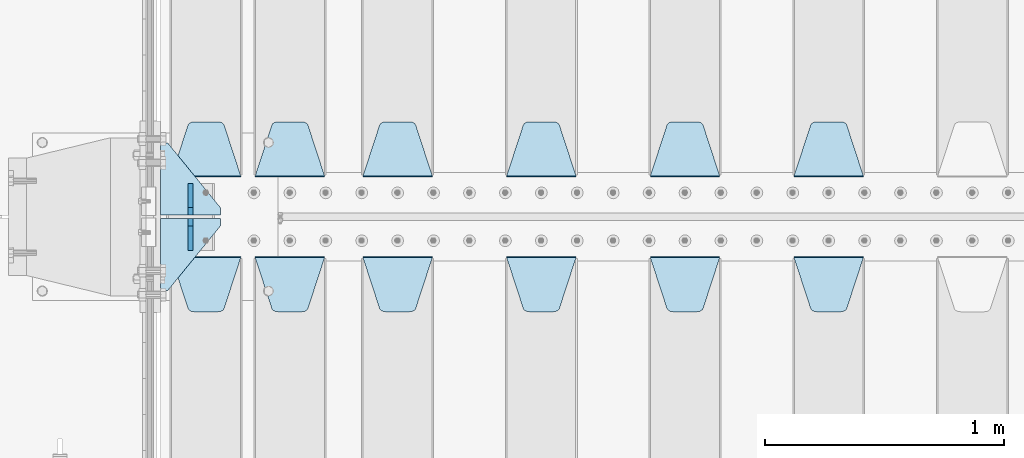
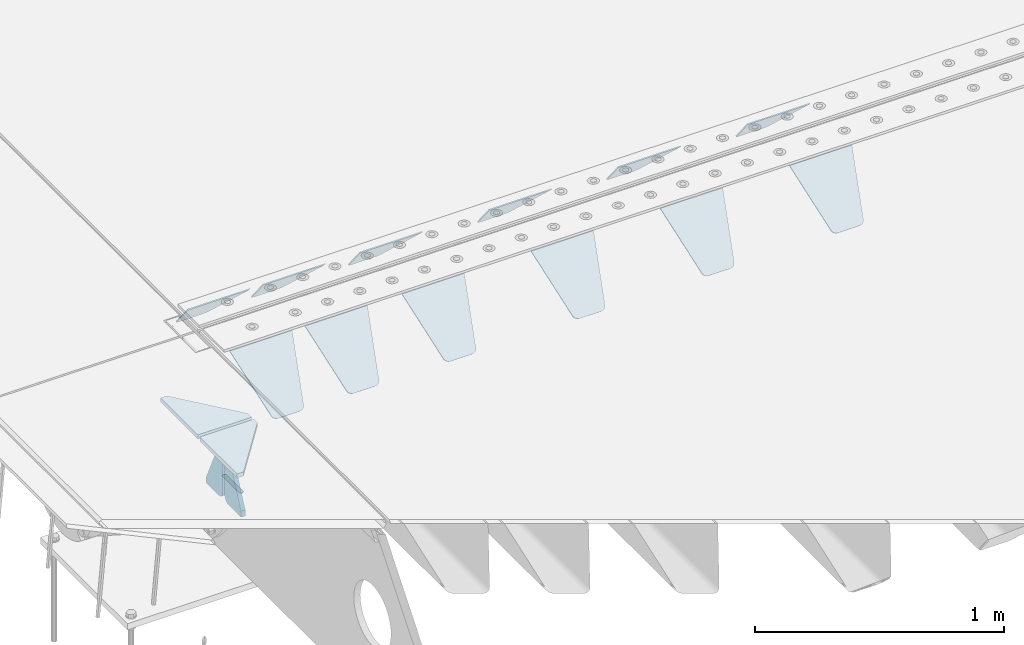
# One storey, part 206 of 257: 16 plates.
"""IFC2X3 building model written with IfcOpenShell, lengths in millimetres."""

from ifc_helpers import new_model, si_unit, frame, origin_with_axes, place, context, subcontext, project, spatial, faceted_brep, material, type_object, element, save


model = new_model("IFC2X3")

# Units and contexts
model_context = context("Model", 3, precision=1e-05, world=origin_with_axes())
body_context = subcontext(model_context, "Body", "Model", "MODEL_VIEW")
ifc_project = project(units=[si_unit("LENGTHUNIT", "METRE", prefix="MILLI"), si_unit("AREAUNIT", "SQUARE_METRE"), si_unit("VOLUMEUNIT", "CUBIC_METRE"), si_unit("MASSUNIT", "GRAM", prefix="KILO"), si_unit("TIMEUNIT", "SECOND"), si_unit("PLANEANGLEUNIT", "RADIAN"), si_unit("SOLIDANGLEUNIT", "STERADIAN"), si_unit("THERMODYNAMICTEMPERATUREUNIT", "DEGREE_CELSIUS"), si_unit("LUMINOUSINTENSITYUNIT", "LUMEN")], contexts=[model_context])

# Site, building, storey
site_placement = place(None, origin_with_axes())
site = spatial("IfcSite", under=ifc_project, at=site_placement, CompositionType="ELEMENT")
building_placement = place(site_placement, origin_with_axes())
building = spatial("IfcBuilding", under=site, at=building_placement, Name="Standard", CompositionType="ELEMENT")
storey_placement = place(building_placement, origin_with_axes())
storey = spatial("IfcBuildingStorey", under=building, at=storey_placement, Name="Undefined", CompositionType="ELEMENT", Elevation=0.0)

# Plates
ifc_material = material(Name="STEEL/S355N")
plate_type_1 = type_object("IfcPlateType", PredefinedType="NOTDEFINED")
plate_1_placement = place(storey_placement, frame((45395.0, 6168.23223304703, -1.76776695296758), z_axis=(0.0, 0.707106781186547, -0.707106781186548), x_axis=(-1.0, 0.0, 0.0)))
element("IfcPlate", 1, at=plate_1_placement, inside=storey, type_object=plate_type_1, material=ifc_material, context=body_context, shape_type="Brep", body=[
    faceted_brep([(0.0, -2.5, 0.0), (69.345504679477, -2.50000000000091, 300.17173142483), (69.345504679477, 2.5, 300.171731424831), (0.0, 2.5, 0.0), (70.927406119954, -2.50000000000091, 304.8974424154), (70.927406119954, 2.5, 304.8974424154), (73.3818627772271, -2.50000000000091, 309.234538108527), (73.3818627772271, 2.49999999999909, 309.234538108527), (76.6187032999587, -2.5, 313.023683126103), (76.6187032999587, 2.5, 313.023683126103), (80.5190132705029, -2.5, 316.125672595372), (80.5190132705029, 2.5, 316.125672595371), (84.9395038596849, -2.5, 318.426546230476), (84.9395038596849, 2.5, 318.426546230477), (89.7177759439219, -2.5, 319.841774983275), (89.7177759439219, 2.5, 319.841774983275), (94.6782862926484, -2.5, 320.319366455079), (94.6782862926484, 2.5, 320.319366455079), (195.321713707352, -2.5, 320.319366455079), (195.321713707352, 2.5, 320.319366455079), (200.282224056078, -2.5, 319.841774983275), (200.282224056078, 2.49999999999909, 319.841774983275), (205.060496140315, -2.5, 318.426546230476), (205.060496140315, 2.49999999999909, 318.426546230475), (209.480986729497, -2.5, 316.125672595371), (209.480986729497, 2.5, 316.125672595371), (213.381296700041, -2.50000000000091, 313.023683126102), (213.381296700041, 2.5, 313.023683126103), (216.618137222766, -2.50000000000091, 309.234538108527), (216.618137222766, 2.5, 309.234538108527), (219.072593880039, -2.5, 304.897442415399), (219.072593880039, 2.5, 304.897442415399), (220.654495320523, -2.50000000000091, 300.17173142483), (220.654495320523, 2.5, 300.171731424831), (290.0, -2.50000000000091, 0.0), (290.0, 2.5, 9.09494701772928e-13)], [[[0, 1, 2, 3]], [[1, 4, 5, 2]], [[4, 6, 7, 5]], [[6, 8, 9, 7]], [[8, 10, 11, 9]], [[10, 12, 13, 11]], [[12, 14, 15, 13]], [[14, 16, 17, 15]], [[16, 18, 19, 17]], [[18, 20, 21, 19]], [[20, 22, 23, 21]], [[22, 24, 25, 23]], [[24, 26, 27, 25]], [[26, 28, 29, 27]], [[28, 30, 31, 29]], [[30, 32, 33, 31]], [[32, 34, 35, 33]], [[34, 0, 3, 35]], [[5, 7, 9, 11, 13, 15, 17, 19, 21, 23, 25, 27, 29, 31, 33, 35, 3, 2]], [[34, 32, 30, 28, 26, 24, 22, 20, 18, 16, 14, 12, 10, 8, 6, 4, 1, 0]]]),
])
plate_2_placement = place(storey_placement, frame((44795.0, 6168.23223304703, -1.76776695296758), z_axis=(0.0, 0.707106781186547, -0.707106781186548), x_axis=(-1.0, 0.0, 0.0)))
element("IfcPlate", 2, at=plate_2_placement, inside=storey, type_object=plate_type_1, material=ifc_material, context=body_context, shape_type="Brep", body=[
    faceted_brep([(0.0, -2.5, 0.0), (69.345504679477, -2.50000000000091, 300.17173142483), (69.345504679477, 2.5, 300.171731424831), (0.0, 2.5, 0.0), (70.927406119954, -2.50000000000091, 304.8974424154), (70.927406119954, 2.5, 304.8974424154), (73.3818627772271, -2.50000000000091, 309.234538108527), (73.3818627772271, 2.49999999999909, 309.234538108527), (76.6187032999587, -2.5, 313.023683126103), (76.6187032999587, 2.5, 313.023683126103), (80.5190132705029, -2.5, 316.125672595372), (80.5190132705029, 2.5, 316.125672595371), (84.9395038596849, -2.5, 318.426546230476), (84.9395038596849, 2.5, 318.426546230477), (89.7177759439219, -2.5, 319.841774983275), (89.7177759439219, 2.5, 319.841774983275), (94.6782862926484, -2.5, 320.319366455079), (94.6782862926484, 2.5, 320.319366455079), (195.321713707352, -2.5, 320.319366455079), (195.321713707352, 2.5, 320.319366455079), (200.282224056078, -2.5, 319.841774983275), (200.282224056078, 2.49999999999909, 319.841774983275), (205.060496140315, -2.5, 318.426546230476), (205.060496140315, 2.49999999999909, 318.426546230475), (209.480986729497, -2.5, 316.125672595371), (209.480986729497, 2.5, 316.125672595371), (213.381296700041, -2.50000000000091, 313.023683126102), (213.381296700041, 2.5, 313.023683126103), (216.618137222766, -2.50000000000091, 309.234538108527), (216.618137222766, 2.5, 309.234538108527), (219.072593880039, -2.5, 304.897442415399), (219.072593880039, 2.5, 304.897442415399), (220.654495320523, -2.50000000000091, 300.17173142483), (220.654495320523, 2.5, 300.171731424831), (290.0, -2.50000000000091, 0.0), (290.0, 2.5, 9.09494701772928e-13)], [[[0, 1, 2, 3]], [[1, 4, 5, 2]], [[4, 6, 7, 5]], [[6, 8, 9, 7]], [[8, 10, 11, 9]], [[10, 12, 13, 11]], [[12, 14, 15, 13]], [[14, 16, 17, 15]], [[16, 18, 19, 17]], [[18, 20, 21, 19]], [[20, 22, 23, 21]], [[22, 24, 25, 23]], [[24, 26, 27, 25]], [[26, 28, 29, 27]], [[28, 30, 31, 29]], [[30, 32, 33, 31]], [[32, 34, 35, 33]], [[34, 0, 3, 35]], [[5, 7, 9, 11, 13, 15, 17, 19, 21, 23, 25, 27, 29, 31, 33, 35, 3, 2]], [[34, 32, 30, 28, 26, 24, 22, 20, 18, 16, 14, 12, 10, 8, 6, 4, 1, 0]]]),
])
plate_3_placement = place(storey_placement, frame((44195.0, 6168.23223304703, -1.76776695296758), z_axis=(0.0, 0.707106781186547, -0.707106781186548), x_axis=(-1.0, 0.0, 0.0)))
element("IfcPlate", 3, at=plate_3_placement, inside=storey, type_object=plate_type_1, material=ifc_material, context=body_context, shape_type="Brep", body=[
    faceted_brep([(0.0, -2.5, 0.0), (69.345504679477, -2.50000000000091, 300.17173142483), (69.345504679477, 2.5, 300.171731424831), (0.0, 2.5, 0.0), (70.927406119954, -2.50000000000091, 304.8974424154), (70.927406119954, 2.5, 304.8974424154), (73.3818627772271, -2.50000000000091, 309.234538108527), (73.3818627772271, 2.49999999999909, 309.234538108527), (76.6187032999587, -2.5, 313.023683126103), (76.6187032999587, 2.5, 313.023683126103), (80.5190132705029, -2.5, 316.125672595372), (80.5190132705029, 2.5, 316.125672595371), (84.9395038596849, -2.5, 318.426546230476), (84.9395038596849, 2.5, 318.426546230477), (89.7177759439219, -2.5, 319.841774983275), (89.7177759439219, 2.5, 319.841774983275), (94.6782862926484, -2.5, 320.319366455079), (94.6782862926484, 2.5, 320.319366455079), (195.321713707352, -2.5, 320.319366455079), (195.321713707352, 2.5, 320.319366455079), (200.282224056078, -2.5, 319.841774983275), (200.282224056078, 2.49999999999909, 319.841774983275), (205.060496140315, -2.5, 318.426546230476), (205.060496140315, 2.49999999999909, 318.426546230475), (209.480986729497, -2.5, 316.125672595371), (209.480986729497, 2.5, 316.125672595371), (213.381296700041, -2.50000000000091, 313.023683126102), (213.381296700041, 2.5, 313.023683126103), (216.618137222766, -2.50000000000091, 309.234538108527), (216.618137222766, 2.5, 309.234538108527), (219.072593880039, -2.5, 304.897442415399), (219.072593880039, 2.5, 304.897442415399), (220.654495320523, -2.50000000000091, 300.17173142483), (220.654495320523, 2.5, 300.171731424831), (290.0, -2.50000000000091, 0.0), (290.0, 2.5, 9.09494701772928e-13)], [[[0, 1, 2, 3]], [[1, 4, 5, 2]], [[4, 6, 7, 5]], [[6, 8, 9, 7]], [[8, 10, 11, 9]], [[10, 12, 13, 11]], [[12, 14, 15, 13]], [[14, 16, 17, 15]], [[16, 18, 19, 17]], [[18, 20, 21, 19]], [[20, 22, 23, 21]], [[22, 24, 25, 23]], [[24, 26, 27, 25]], [[26, 28, 29, 27]], [[28, 30, 31, 29]], [[30, 32, 33, 31]], [[32, 34, 35, 33]], [[34, 0, 3, 35]], [[5, 7, 9, 11, 13, 15, 17, 19, 21, 23, 25, 27, 29, 31, 33, 35, 3, 2]], [[34, 32, 30, 28, 26, 24, 22, 20, 18, 16, 14, 12, 10, 8, 6, 4, 1, 0]]]),
])
plate_4_placement = place(storey_placement, frame((43595.0, 6168.23223304703, -1.76776695296758), z_axis=(0.0, 0.707106781186547, -0.707106781186548), x_axis=(-1.0, 0.0, 0.0)))
element("IfcPlate", 4, at=plate_4_placement, inside=storey, type_object=plate_type_1, material=ifc_material, context=body_context, shape_type="Brep", body=[
    faceted_brep([(0.0, -2.5, 0.0), (69.345504679477, -2.50000000000091, 300.17173142483), (69.345504679477, 2.5, 300.171731424831), (0.0, 2.5, 0.0), (70.927406119954, -2.50000000000091, 304.8974424154), (70.927406119954, 2.5, 304.8974424154), (73.3818627772271, -2.50000000000091, 309.234538108527), (73.3818627772271, 2.49999999999909, 309.234538108527), (76.6187032999587, -2.5, 313.023683126103), (76.6187032999587, 2.5, 313.023683126103), (80.5190132705029, -2.5, 316.125672595372), (80.5190132705029, 2.5, 316.125672595371), (84.9395038596849, -2.5, 318.426546230476), (84.9395038596849, 2.5, 318.426546230477), (89.7177759439219, -2.5, 319.841774983275), (89.7177759439219, 2.5, 319.841774983275), (94.6782862926484, -2.5, 320.319366455079), (94.6782862926484, 2.5, 320.319366455079), (195.321713707352, -2.5, 320.319366455079), (195.321713707352, 2.5, 320.319366455079), (200.282224056078, -2.5, 319.841774983275), (200.282224056078, 2.49999999999909, 319.841774983275), (205.060496140315, -2.5, 318.426546230476), (205.060496140315, 2.49999999999909, 318.426546230475), (209.480986729497, -2.5, 316.125672595371), (209.480986729497, 2.5, 316.125672595371), (213.381296700041, -2.50000000000091, 313.023683126102), (213.381296700041, 2.5, 313.023683126103), (216.618137222766, -2.50000000000091, 309.234538108527), (216.618137222766, 2.5, 309.234538108527), (219.072593880039, -2.5, 304.897442415399), (219.072593880039, 2.5, 304.897442415399), (220.654495320523, -2.50000000000091, 300.17173142483), (220.654495320523, 2.5, 300.171731424831), (290.0, -2.50000000000091, 0.0), (290.0, 2.5, 9.09494701772928e-13)], [[[0, 1, 2, 3]], [[1, 4, 5, 2]], [[4, 6, 7, 5]], [[6, 8, 9, 7]], [[8, 10, 11, 9]], [[10, 12, 13, 11]], [[12, 14, 15, 13]], [[14, 16, 17, 15]], [[16, 18, 19, 17]], [[18, 20, 21, 19]], [[20, 22, 23, 21]], [[22, 24, 25, 23]], [[24, 26, 27, 25]], [[26, 28, 29, 27]], [[28, 30, 31, 29]], [[30, 32, 33, 31]], [[32, 34, 35, 33]], [[34, 0, 3, 35]], [[5, 7, 9, 11, 13, 15, 17, 19, 21, 23, 25, 27, 29, 31, 33, 35, 3, 2]], [[34, 32, 30, 28, 26, 24, 22, 20, 18, 16, 14, 12, 10, 8, 6, 4, 1, 0]]]),
])
plate_5_placement = place(storey_placement, frame((43145.0, 6168.23223304703, -1.76776695296758), z_axis=(0.0, 0.707106781186547, -0.707106781186548), x_axis=(-1.0, 0.0, 0.0)))
element("IfcPlate", 5, at=plate_5_placement, inside=storey, type_object=plate_type_1, material=ifc_material, context=body_context, shape_type="Brep", body=[
    faceted_brep([(0.0, -2.5, 0.0), (69.345504679477, -2.50000000000091, 300.17173142483), (69.345504679477, 2.5, 300.171731424831), (0.0, 2.5, 0.0), (70.927406119954, -2.50000000000091, 304.8974424154), (70.927406119954, 2.5, 304.8974424154), (73.3818627772271, -2.50000000000091, 309.234538108527), (73.3818627772271, 2.49999999999909, 309.234538108527), (76.6187032999587, -2.5, 313.023683126103), (76.6187032999587, 2.5, 313.023683126103), (80.5190132705029, -2.5, 316.125672595372), (80.5190132705029, 2.5, 316.125672595371), (84.9395038596849, -2.5, 318.426546230476), (84.9395038596849, 2.5, 318.426546230477), (89.7177759439219, -2.5, 319.841774983275), (89.7177759439219, 2.5, 319.841774983275), (94.6782862926484, -2.5, 320.319366455079), (94.6782862926484, 2.5, 320.319366455079), (195.321713707352, -2.5, 320.319366455079), (195.321713707352, 2.5, 320.319366455079), (200.282224056078, -2.5, 319.841774983275), (200.282224056078, 2.49999999999909, 319.841774983275), (205.060496140315, -2.5, 318.426546230476), (205.060496140315, 2.49999999999909, 318.426546230475), (209.480986729497, -2.5, 316.125672595371), (209.480986729497, 2.5, 316.125672595371), (213.381296700041, -2.50000000000091, 313.023683126102), (213.381296700041, 2.5, 313.023683126103), (216.618137222766, -2.50000000000091, 309.234538108527), (216.618137222766, 2.5, 309.234538108527), (219.072593880039, -2.5, 304.897442415399), (219.072593880039, 2.5, 304.897442415399), (220.654495320523, -2.50000000000091, 300.17173142483), (220.654495320523, 2.5, 300.171731424831), (290.0, -2.50000000000091, 0.0), (290.0, 2.5, 9.09494701772928e-13)], [[[0, 1, 2, 3]], [[1, 4, 5, 2]], [[4, 6, 7, 5]], [[6, 8, 9, 7]], [[8, 10, 11, 9]], [[10, 12, 13, 11]], [[12, 14, 15, 13]], [[14, 16, 17, 15]], [[16, 18, 19, 17]], [[18, 20, 21, 19]], [[20, 22, 23, 21]], [[22, 24, 25, 23]], [[24, 26, 27, 25]], [[26, 28, 29, 27]], [[28, 30, 31, 29]], [[30, 32, 33, 31]], [[32, 34, 35, 33]], [[34, 0, 3, 35]], [[5, 7, 9, 11, 13, 15, 17, 19, 21, 23, 25, 27, 29, 31, 33, 35, 3, 2]], [[34, 32, 30, 28, 26, 24, 22, 20, 18, 16, 14, 12, 10, 8, 6, 4, 1, 0]]]),
])
plate_6_placement = place(storey_placement, frame((45105.0, 5831.76776695594, -1.767766952965), z_axis=(0.0, -0.707106781186548, -0.707106781186547), x_axis=(1.0, 0.0, 0.0)))
element("IfcPlate", 6, at=plate_6_placement, inside=storey, type_object=plate_type_1, material=ifc_material, context=body_context, shape_type="Brep", body=[
    faceted_brep([(0.0, -2.5, 0.0), (69.345504679477, -2.50000000000091, 300.17173142483), (69.345504679477, 2.5, 300.171731424831), (0.0, 2.5, 0.0), (70.927406119954, -2.50000000000091, 304.8974424154), (70.927406119954, 2.5, 304.8974424154), (73.3818627772271, -2.50000000000091, 309.234538108527), (73.3818627772271, 2.49999999999909, 309.234538108527), (76.6187032999587, -2.5, 313.023683126103), (76.6187032999587, 2.5, 313.023683126103), (80.5190132705029, -2.5, 316.125672595372), (80.5190132705029, 2.5, 316.125672595371), (84.9395038596849, -2.5, 318.426546230476), (84.9395038596849, 2.5, 318.426546230477), (89.7177759439219, -2.5, 319.841774983275), (89.7177759439219, 2.5, 319.841774983275), (94.6782862926484, -2.5, 320.319366455079), (94.6782862926484, 2.5, 320.319366455079), (195.321713707352, -2.5, 320.319366455079), (195.321713707352, 2.5, 320.319366455079), (200.282224056078, -2.5, 319.841774983275), (200.282224056078, 2.49999999999909, 319.841774983275), (205.060496140315, -2.5, 318.426546230476), (205.060496140315, 2.49999999999909, 318.426546230475), (209.480986729497, -2.5, 316.125672595371), (209.480986729497, 2.5, 316.125672595371), (213.381296700041, -2.50000000000091, 313.023683126102), (213.381296700041, 2.5, 313.023683126103), (216.618137222766, -2.50000000000091, 309.234538108527), (216.618137222766, 2.5, 309.234538108527), (219.072593880039, -2.5, 304.897442415399), (219.072593880039, 2.5, 304.897442415399), (220.654495320523, -2.50000000000091, 300.17173142483), (220.654495320523, 2.5, 300.171731424831), (290.0, -2.50000000000091, 0.0), (290.0, 2.5, 9.09494701772928e-13)], [[[0, 1, 2, 3]], [[1, 4, 5, 2]], [[4, 6, 7, 5]], [[6, 8, 9, 7]], [[8, 10, 11, 9]], [[10, 12, 13, 11]], [[12, 14, 15, 13]], [[14, 16, 17, 15]], [[16, 18, 19, 17]], [[18, 20, 21, 19]], [[20, 22, 23, 21]], [[22, 24, 25, 23]], [[24, 26, 27, 25]], [[26, 28, 29, 27]], [[28, 30, 31, 29]], [[30, 32, 33, 31]], [[32, 34, 35, 33]], [[34, 0, 3, 35]], [[5, 7, 9, 11, 13, 15, 17, 19, 21, 23, 25, 27, 29, 31, 33, 35, 3, 2]], [[34, 32, 30, 28, 26, 24, 22, 20, 18, 16, 14, 12, 10, 8, 6, 4, 1, 0]]]),
])
plate_7_placement = place(storey_placement, frame((44505.0, 5831.76776695594, -1.767766952965), z_axis=(0.0, -0.707106781186548, -0.707106781186547), x_axis=(1.0, 0.0, 0.0)))
element("IfcPlate", 7, at=plate_7_placement, inside=storey, type_object=plate_type_1, material=ifc_material, context=body_context, shape_type="Brep", body=[
    faceted_brep([(0.0, -2.5, 0.0), (69.345504679477, -2.50000000000091, 300.17173142483), (69.345504679477, 2.5, 300.171731424831), (0.0, 2.5, 0.0), (70.927406119954, -2.50000000000091, 304.8974424154), (70.927406119954, 2.5, 304.8974424154), (73.3818627772271, -2.50000000000091, 309.234538108527), (73.3818627772271, 2.49999999999909, 309.234538108527), (76.6187032999587, -2.5, 313.023683126103), (76.6187032999587, 2.5, 313.023683126103), (80.5190132705029, -2.5, 316.125672595372), (80.5190132705029, 2.5, 316.125672595371), (84.9395038596849, -2.5, 318.426546230476), (84.9395038596849, 2.5, 318.426546230477), (89.7177759439219, -2.5, 319.841774983275), (89.7177759439219, 2.5, 319.841774983275), (94.6782862926484, -2.5, 320.319366455079), (94.6782862926484, 2.5, 320.319366455079), (195.321713707352, -2.5, 320.319366455079), (195.321713707352, 2.5, 320.319366455079), (200.282224056078, -2.5, 319.841774983275), (200.282224056078, 2.49999999999909, 319.841774983275), (205.060496140315, -2.5, 318.426546230476), (205.060496140315, 2.49999999999909, 318.426546230475), (209.480986729497, -2.5, 316.125672595371), (209.480986729497, 2.5, 316.125672595371), (213.381296700041, -2.50000000000091, 313.023683126102), (213.381296700041, 2.5, 313.023683126103), (216.618137222766, -2.50000000000091, 309.234538108527), (216.618137222766, 2.5, 309.234538108527), (219.072593880039, -2.5, 304.897442415399), (219.072593880039, 2.5, 304.897442415399), (220.654495320523, -2.50000000000091, 300.17173142483), (220.654495320523, 2.5, 300.171731424831), (290.0, -2.50000000000091, 0.0), (290.0, 2.5, 9.09494701772928e-13)], [[[0, 1, 2, 3]], [[1, 4, 5, 2]], [[4, 6, 7, 5]], [[6, 8, 9, 7]], [[8, 10, 11, 9]], [[10, 12, 13, 11]], [[12, 14, 15, 13]], [[14, 16, 17, 15]], [[16, 18, 19, 17]], [[18, 20, 21, 19]], [[20, 22, 23, 21]], [[22, 24, 25, 23]], [[24, 26, 27, 25]], [[26, 28, 29, 27]], [[28, 30, 31, 29]], [[30, 32, 33, 31]], [[32, 34, 35, 33]], [[34, 0, 3, 35]], [[5, 7, 9, 11, 13, 15, 17, 19, 21, 23, 25, 27, 29, 31, 33, 35, 3, 2]], [[34, 32, 30, 28, 26, 24, 22, 20, 18, 16, 14, 12, 10, 8, 6, 4, 1, 0]]]),
])
plate_8_placement = place(storey_placement, frame((43905.0, 5831.76776695594, -1.767766952965), z_axis=(0.0, -0.707106781186548, -0.707106781186547), x_axis=(1.0, 0.0, 0.0)))
element("IfcPlate", 8, at=plate_8_placement, inside=storey, type_object=plate_type_1, material=ifc_material, context=body_context, shape_type="Brep", body=[
    faceted_brep([(0.0, -2.5, 0.0), (69.345504679477, -2.50000000000091, 300.17173142483), (69.345504679477, 2.5, 300.171731424831), (0.0, 2.5, 0.0), (70.927406119954, -2.50000000000091, 304.8974424154), (70.927406119954, 2.5, 304.8974424154), (73.3818627772271, -2.50000000000091, 309.234538108527), (73.3818627772271, 2.49999999999909, 309.234538108527), (76.6187032999587, -2.5, 313.023683126103), (76.6187032999587, 2.5, 313.023683126103), (80.5190132705029, -2.5, 316.125672595372), (80.5190132705029, 2.5, 316.125672595371), (84.9395038596849, -2.5, 318.426546230476), (84.9395038596849, 2.5, 318.426546230477), (89.7177759439219, -2.5, 319.841774983275), (89.7177759439219, 2.5, 319.841774983275), (94.6782862926484, -2.5, 320.319366455079), (94.6782862926484, 2.5, 320.319366455079), (195.321713707352, -2.5, 320.319366455079), (195.321713707352, 2.5, 320.319366455079), (200.282224056078, -2.5, 319.841774983275), (200.282224056078, 2.49999999999909, 319.841774983275), (205.060496140315, -2.5, 318.426546230476), (205.060496140315, 2.49999999999909, 318.426546230475), (209.480986729497, -2.5, 316.125672595371), (209.480986729497, 2.5, 316.125672595371), (213.381296700041, -2.50000000000091, 313.023683126102), (213.381296700041, 2.5, 313.023683126103), (216.618137222766, -2.50000000000091, 309.234538108527), (216.618137222766, 2.5, 309.234538108527), (219.072593880039, -2.5, 304.897442415399), (219.072593880039, 2.5, 304.897442415399), (220.654495320523, -2.50000000000091, 300.17173142483), (220.654495320523, 2.5, 300.171731424831), (290.0, -2.50000000000091, 0.0), (290.0, 2.5, 9.09494701772928e-13)], [[[0, 1, 2, 3]], [[1, 4, 5, 2]], [[4, 6, 7, 5]], [[6, 8, 9, 7]], [[8, 10, 11, 9]], [[10, 12, 13, 11]], [[12, 14, 15, 13]], [[14, 16, 17, 15]], [[16, 18, 19, 17]], [[18, 20, 21, 19]], [[20, 22, 23, 21]], [[22, 24, 25, 23]], [[24, 26, 27, 25]], [[26, 28, 29, 27]], [[28, 30, 31, 29]], [[30, 32, 33, 31]], [[32, 34, 35, 33]], [[34, 0, 3, 35]], [[5, 7, 9, 11, 13, 15, 17, 19, 21, 23, 25, 27, 29, 31, 33, 35, 3, 2]], [[34, 32, 30, 28, 26, 24, 22, 20, 18, 16, 14, 12, 10, 8, 6, 4, 1, 0]]]),
])
plate_9_placement = place(storey_placement, frame((43305.0, 5831.76776695594, -1.767766952965), z_axis=(0.0, -0.707106781186548, -0.707106781186547), x_axis=(1.0, 0.0, 0.0)))
element("IfcPlate", 9, at=plate_9_placement, inside=storey, type_object=plate_type_1, material=ifc_material, context=body_context, shape_type="Brep", body=[
    faceted_brep([(0.0, -2.5, 0.0), (69.345504679477, -2.50000000000091, 300.17173142483), (69.345504679477, 2.5, 300.171731424831), (0.0, 2.5, 0.0), (70.927406119954, -2.50000000000091, 304.8974424154), (70.927406119954, 2.5, 304.8974424154), (73.3818627772271, -2.50000000000091, 309.234538108527), (73.3818627772271, 2.49999999999909, 309.234538108527), (76.6187032999587, -2.5, 313.023683126103), (76.6187032999587, 2.5, 313.023683126103), (80.5190132705029, -2.5, 316.125672595372), (80.5190132705029, 2.5, 316.125672595371), (84.9395038596849, -2.5, 318.426546230476), (84.9395038596849, 2.5, 318.426546230477), (89.7177759439219, -2.5, 319.841774983275), (89.7177759439219, 2.5, 319.841774983275), (94.6782862926484, -2.5, 320.319366455079), (94.6782862926484, 2.5, 320.319366455079), (195.321713707352, -2.5, 320.319366455079), (195.321713707352, 2.5, 320.319366455079), (200.282224056078, -2.5, 319.841774983275), (200.282224056078, 2.49999999999909, 319.841774983275), (205.060496140315, -2.5, 318.426546230476), (205.060496140315, 2.49999999999909, 318.426546230475), (209.480986729497, -2.5, 316.125672595371), (209.480986729497, 2.5, 316.125672595371), (213.381296700041, -2.50000000000091, 313.023683126102), (213.381296700041, 2.5, 313.023683126103), (216.618137222766, -2.50000000000091, 309.234538108527), (216.618137222766, 2.5, 309.234538108527), (219.072593880039, -2.5, 304.897442415399), (219.072593880039, 2.5, 304.897442415399), (220.654495320523, -2.50000000000091, 300.17173142483), (220.654495320523, 2.5, 300.171731424831), (290.0, -2.50000000000091, 0.0), (290.0, 2.5, 9.09494701772928e-13)], [[[0, 1, 2, 3]], [[1, 4, 5, 2]], [[4, 6, 7, 5]], [[6, 8, 9, 7]], [[8, 10, 11, 9]], [[10, 12, 13, 11]], [[12, 14, 15, 13]], [[14, 16, 17, 15]], [[16, 18, 19, 17]], [[18, 20, 21, 19]], [[20, 22, 23, 21]], [[22, 24, 25, 23]], [[24, 26, 27, 25]], [[26, 28, 29, 27]], [[28, 30, 31, 29]], [[30, 32, 33, 31]], [[32, 34, 35, 33]], [[34, 0, 3, 35]], [[5, 7, 9, 11, 13, 15, 17, 19, 21, 23, 25, 27, 29, 31, 33, 35, 3, 2]], [[34, 32, 30, 28, 26, 24, 22, 20, 18, 16, 14, 12, 10, 8, 6, 4, 1, 0]]]),
])
plate_10_placement = place(storey_placement, frame((42855.0, 5831.76776695594, -1.767766952965), z_axis=(0.0, -0.707106781186548, -0.707106781186547), x_axis=(1.0, 0.0, 0.0)))
element("IfcPlate", 10, at=plate_10_placement, inside=storey, type_object=plate_type_1, material=ifc_material, context=body_context, shape_type="Brep", body=[
    faceted_brep([(0.0, -2.5, 0.0), (69.345504679477, -2.50000000000091, 300.17173142483), (69.345504679477, 2.5, 300.171731424831), (0.0, 2.5, 0.0), (70.927406119954, -2.50000000000091, 304.8974424154), (70.927406119954, 2.5, 304.8974424154), (73.3818627772271, -2.50000000000091, 309.234538108527), (73.3818627772271, 2.49999999999909, 309.234538108527), (76.6187032999587, -2.5, 313.023683126103), (76.6187032999587, 2.5, 313.023683126103), (80.5190132705029, -2.5, 316.125672595372), (80.5190132705029, 2.5, 316.125672595371), (84.9395038596849, -2.5, 318.426546230476), (84.9395038596849, 2.5, 318.426546230477), (89.7177759439219, -2.5, 319.841774983275), (89.7177759439219, 2.5, 319.841774983275), (94.6782862926484, -2.5, 320.319366455079), (94.6782862926484, 2.5, 320.319366455079), (195.321713707352, -2.5, 320.319366455079), (195.321713707352, 2.5, 320.319366455079), (200.282224056078, -2.5, 319.841774983275), (200.282224056078, 2.49999999999909, 319.841774983275), (205.060496140315, -2.5, 318.426546230476), (205.060496140315, 2.49999999999909, 318.426546230475), (209.480986729497, -2.5, 316.125672595371), (209.480986729497, 2.5, 316.125672595371), (213.381296700041, -2.50000000000091, 313.023683126102), (213.381296700041, 2.5, 313.023683126103), (216.618137222766, -2.50000000000091, 309.234538108527), (216.618137222766, 2.5, 309.234538108527), (219.072593880039, -2.5, 304.897442415399), (219.072593880039, 2.5, 304.897442415399), (220.654495320523, -2.50000000000091, 300.17173142483), (220.654495320523, 2.5, 300.171731424831), (290.0, -2.50000000000091, 0.0), (290.0, 2.5, 9.09494701772928e-13)], [[[0, 1, 2, 3]], [[1, 4, 5, 2]], [[4, 6, 7, 5]], [[6, 8, 9, 7]], [[8, 10, 11, 9]], [[10, 12, 13, 11]], [[12, 14, 15, 13]], [[14, 16, 17, 15]], [[16, 18, 19, 17]], [[18, 20, 21, 19]], [[20, 22, 23, 21]], [[22, 24, 25, 23]], [[24, 26, 27, 25]], [[26, 28, 29, 27]], [[28, 30, 31, 29]], [[30, 32, 33, 31]], [[32, 34, 35, 33]], [[34, 0, 3, 35]], [[5, 7, 9, 11, 13, 15, 17, 19, 21, 23, 25, 27, 29, 31, 33, 35, 3, 2]], [[34, 32, 30, 28, 26, 24, 22, 20, 18, 16, 14, 12, 10, 8, 6, 4, 1, 0]]]),
])
plate_11_placement = place(storey_placement, frame((42795.0, 6168.23223304703, -1.76776695296758), z_axis=(0.0, 0.707106781186547, -0.707106781186548), x_axis=(-1.0, 0.0, 0.0)))
element("IfcPlate", 11, at=plate_11_placement, inside=storey, type_object=plate_type_1, material=ifc_material, context=body_context, shape_type="Brep", body=[
    faceted_brep([(0.0, -2.5, 0.0), (69.345504679477, -2.50000000000091, 300.17173142483), (69.345504679477, 2.5, 300.171731424831), (0.0, 2.5, 0.0), (70.927406119954, -2.50000000000091, 304.8974424154), (70.927406119954, 2.5, 304.8974424154), (73.3818627772271, -2.50000000000091, 309.234538108527), (73.3818627772271, 2.49999999999909, 309.234538108527), (76.6187032999587, -2.5, 313.023683126103), (76.6187032999587, 2.5, 313.023683126103), (80.5190132705029, -2.5, 316.125672595372), (80.5190132705029, 2.5, 316.125672595371), (84.9395038596849, -2.5, 318.426546230476), (84.9395038596849, 2.5, 318.426546230477), (89.7177759439219, -2.5, 319.841774983275), (89.7177759439219, 2.5, 319.841774983275), (94.6782862926484, -2.5, 320.319366455079), (94.6782862926484, 2.5, 320.319366455079), (195.321713707352, -2.5, 320.319366455079), (195.321713707352, 2.5, 320.319366455079), (200.282224056078, -2.5, 319.841774983275), (200.282224056078, 2.49999999999909, 319.841774983275), (205.060496140315, -2.5, 318.426546230476), (205.060496140315, 2.49999999999909, 318.426546230475), (209.480986729497, -2.5, 316.125672595371), (209.480986729497, 2.5, 316.125672595371), (213.381296700041, -2.50000000000091, 313.023683126102), (213.381296700041, 2.5, 313.023683126103), (216.618137222766, -2.50000000000091, 309.234538108527), (216.618137222766, 2.5, 309.234538108527), (219.072593880039, -2.5, 304.897442415399), (219.072593880039, 2.5, 304.897442415399), (220.654495320523, -2.50000000000091, 300.17173142483), (220.654495320523, 2.5, 300.171731424831), (290.0, -2.50000000000091, 0.0), (290.0, 2.5, 9.09494701772928e-13)], [[[0, 1, 2, 3]], [[1, 4, 5, 2]], [[4, 6, 7, 5]], [[6, 8, 9, 7]], [[8, 10, 11, 9]], [[10, 12, 13, 11]], [[12, 14, 15, 13]], [[14, 16, 17, 15]], [[16, 18, 19, 17]], [[18, 20, 21, 19]], [[20, 22, 23, 21]], [[22, 24, 25, 23]], [[24, 26, 27, 25]], [[26, 28, 29, 27]], [[28, 30, 31, 29]], [[30, 32, 33, 31]], [[32, 34, 35, 33]], [[34, 0, 3, 35]], [[5, 7, 9, 11, 13, 15, 17, 19, 21, 23, 25, 27, 29, 31, 33, 35, 3, 2]], [[34, 32, 30, 28, 26, 24, 22, 20, 18, 16, 14, 12, 10, 8, 6, 4, 1, 0]]]),
])
plate_12_placement = place(storey_placement, frame((42505.0, 5831.76776695594, -1.767766952965), z_axis=(0.0, -0.707106781186548, -0.707106781186547), x_axis=(1.0, 0.0, 0.0)))
element("IfcPlate", 12, at=plate_12_placement, inside=storey, type_object=plate_type_1, material=ifc_material, context=body_context, shape_type="Brep", body=[
    faceted_brep([(0.0, -2.5, 0.0), (69.345504679477, -2.50000000000091, 300.17173142483), (69.345504679477, 2.5, 300.171731424831), (0.0, 2.5, 0.0), (70.927406119954, -2.50000000000091, 304.8974424154), (70.927406119954, 2.5, 304.8974424154), (73.3818627772271, -2.50000000000091, 309.234538108527), (73.3818627772271, 2.49999999999909, 309.234538108527), (76.6187032999587, -2.5, 313.023683126103), (76.6187032999587, 2.5, 313.023683126103), (80.5190132705029, -2.5, 316.125672595372), (80.5190132705029, 2.5, 316.125672595371), (84.9395038596849, -2.5, 318.426546230476), (84.9395038596849, 2.5, 318.426546230477), (89.7177759439219, -2.5, 319.841774983275), (89.7177759439219, 2.5, 319.841774983275), (94.6782862926484, -2.5, 320.319366455079), (94.6782862926484, 2.5, 320.319366455079), (195.321713707352, -2.5, 320.319366455079), (195.321713707352, 2.5, 320.319366455079), (200.282224056078, -2.5, 319.841774983275), (200.282224056078, 2.49999999999909, 319.841774983275), (205.060496140315, -2.5, 318.426546230476), (205.060496140315, 2.49999999999909, 318.426546230475), (209.480986729497, -2.5, 316.125672595371), (209.480986729497, 2.5, 316.125672595371), (213.381296700041, -2.50000000000091, 313.023683126102), (213.381296700041, 2.5, 313.023683126103), (216.618137222766, -2.50000000000091, 309.234538108527), (216.618137222766, 2.5, 309.234538108527), (219.072593880039, -2.5, 304.897442415399), (219.072593880039, 2.5, 304.897442415399), (220.654495320523, -2.50000000000091, 300.17173142483), (220.654495320523, 2.5, 300.171731424831), (290.0, -2.50000000000091, 0.0), (290.0, 2.5, 9.09494701772928e-13)], [[[0, 1, 2, 3]], [[1, 4, 5, 2]], [[4, 6, 7, 5]], [[6, 8, 9, 7]], [[8, 10, 11, 9]], [[10, 12, 13, 11]], [[12, 14, 15, 13]], [[14, 16, 17, 15]], [[16, 18, 19, 17]], [[18, 20, 21, 19]], [[20, 22, 23, 21]], [[22, 24, 25, 23]], [[24, 26, 27, 25]], [[26, 28, 29, 27]], [[28, 30, 31, 29]], [[30, 32, 33, 31]], [[32, 34, 35, 33]], [[34, 0, 3, 35]], [[5, 7, 9, 11, 13, 15, 17, 19, 21, 23, 25, 27, 29, 31, 33, 35, 3, 2]], [[34, 32, 30, 28, 26, 24, 22, 20, 18, 16, 14, 12, 10, 8, 6, 4, 1, 0]]]),
])
plate_type_2 = type_object("IfcPlateType", PredefinedType="NOTDEFINED")
for number, where, z_axis, x_axis in (
    (13, (42710.0, 6008.0, -515.0), (0.0, 1.0, 0.0), (-1.0, 0.0, 0.0)),
    (14, (42710.0, 5992.0, -515.0), (0.0, -1.0, 0.0), (-1.0, 0.0, 0.0)),
):
    element("IfcPlate", number, at=place(storey_placement, frame(where, z_axis=z_axis, x_axis=x_axis)), inside=storey, type_object=plate_type_2, material=ifc_material, context=body_context, shape_type="Brep", body=[
        faceted_brep([(0.0, -10.0, 0.0), (0.0, -10.0, 30.0), (0.0, 10.0, 30.0), (0.0, 10.0, 0.0), (220.0, -10.0, 300.0), (220.0, 10.0, 300.0), (250.0, -10.0, 300.0), (250.0, 10.0, 300.0), (250.0, -10.0, 0.0), (250.0, 10.0, 0.0)], [[[0, 1, 2, 3]], [[1, 4, 5, 2]], [[4, 6, 7, 5]], [[6, 8, 9, 7]], [[8, 0, 3, 9]], [[5, 7, 9, 3, 2]], [[8, 6, 4, 1, 0]]]),
    ])
plate_type_3 = type_object("IfcPlateType", PredefinedType="NOTDEFINED")
for number, where, z_axis, x_axis in (
    (15, (42585.0, 6140.0, -860.0), (0.0, 0.0, 1.0), (0.0, -1.0, 0.0)),
    (16, (42585.0, 5860.0, -860.0), (0.0, 0.0, 1.0), (0.0, 1.0, 0.0)),
):
    element("IfcPlate", number, at=place(storey_placement, frame(where, z_axis=z_axis, x_axis=x_axis)), inside=storey, type_object=plate_type_3, material=ifc_material, context=body_context, shape_type="Brep", body=[
        faceted_brep([(0.0, -10.0, 0.0), (0.0, -10.0, 30.0), (0.0, 10.0, 30.0), (0.0, 10.0, 0.0), (102.0, -10.0, 250.0), (102.0, 10.0, 250.0), (132.0, -10.0, 250.0), (132.0, 10.0, 250.0), (132.0, -10.0, 30.0), (132.0, 10.0, 30.0), (131.544232590366, -10.0, 24.790554669992), (131.544232590366, 10.0, 24.790554669992), (130.190778623577, -10.0, 19.7393957002299), (130.190778623577, 10.0, 19.7393957002299), (127.980762113533, -10.0, 15.0), (127.980762113533, 10.0, 15.0), (124.981333293569, -10.0, 10.7163717094038), (124.981333293569, 10.0, 10.7163717094038), (121.283628290596, -10.0, 7.01866670643062), (121.283628290596, 10.0, 7.01866670643062), (117.0, -10.0, 4.01923788646684), (117.0, 10.0, 4.01923788646684), (112.26060429977, -10.0, 1.80922137642278), (112.26060429977, 10.0, 1.80922137642278), (107.209445330008, -10.0, 0.455767409633722), (107.209445330008, 10.0, 0.455767409633722), (102.0, -10.0, 0.0), (102.0, 10.0, 0.0)], [[[0, 1, 2, 3]], [[1, 4, 5, 2]], [[4, 6, 7, 5]], [[6, 8, 9, 7]], [[8, 10, 11, 9]], [[10, 12, 13, 11]], [[12, 14, 15, 13]], [[14, 16, 17, 15]], [[16, 18, 19, 17]], [[18, 20, 21, 19]], [[20, 22, 23, 21]], [[22, 24, 25, 23]], [[24, 26, 27, 25]], [[26, 0, 3, 27]], [[5, 7, 9, 11, 13, 15, 17, 19, 21, 23, 25, 27, 3, 2]], [[26, 24, 22, 20, 18, 16, 14, 12, 10, 8, 6, 4, 1, 0]]]),
    ])

save(model, "model.ifc")
